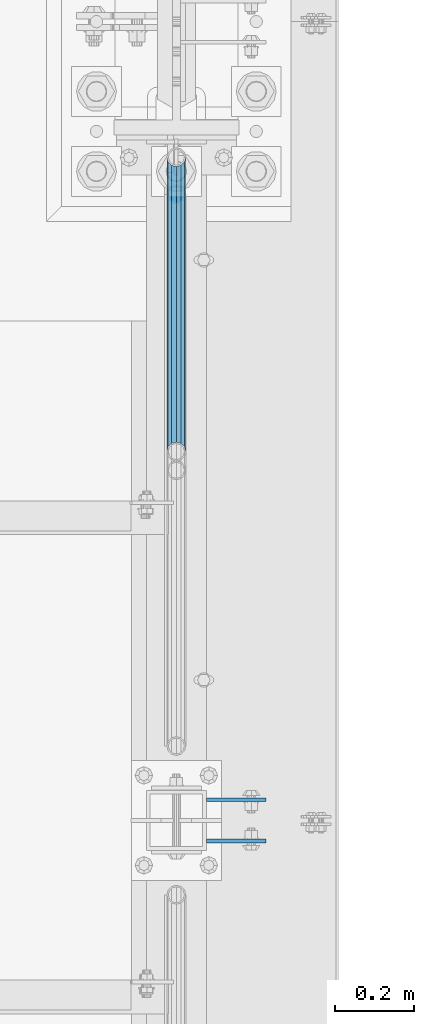
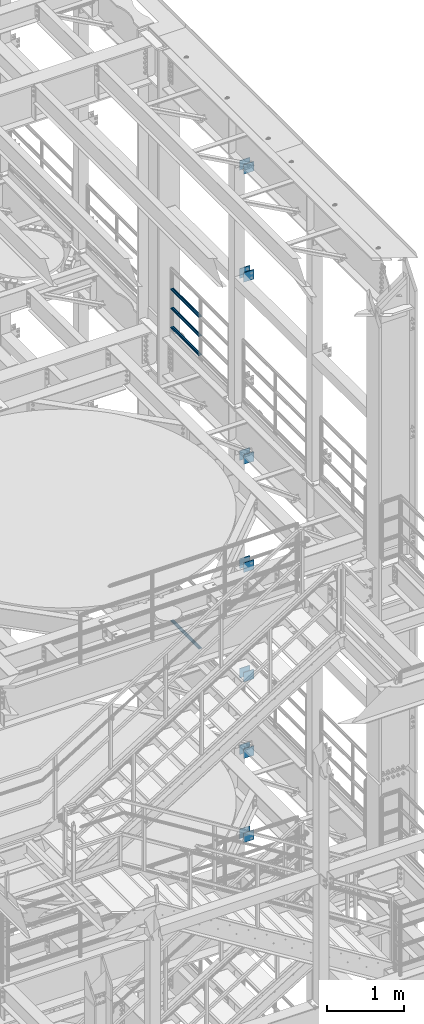
# One storey, part 1269 of 1876: 18 beams, 5 elements without a shape of their own.
"""IFC2X3 building model written with IfcOpenShell, lengths in millimetres."""

from ifc_helpers import new_model, si_unit, frame, origin_with_axes, place, context, subcontext, project, spatial, faceted_brep, material, type_object, element, aggregate, save


model = new_model("IFC2X3")

# Units and contexts
model_context = context("Model", 3, precision=1e-05, world=origin_with_axes())
body_context = subcontext(model_context, "Body", "Model", "MODEL_VIEW")
ifc_project = project(units=[si_unit("LENGTHUNIT", "METRE", prefix="MILLI"), si_unit("AREAUNIT", "SQUARE_METRE"), si_unit("VOLUMEUNIT", "CUBIC_METRE"), si_unit("MASSUNIT", "GRAM", prefix="KILO"), si_unit("TIMEUNIT", "SECOND"), si_unit("PLANEANGLEUNIT", "RADIAN"), si_unit("SOLIDANGLEUNIT", "STERADIAN"), si_unit("THERMODYNAMICTEMPERATUREUNIT", "DEGREE_CELSIUS"), si_unit("LUMINOUSINTENSITYUNIT", "LUMEN")], contexts=[model_context])

# Site, building, storey
site_placement = place(None, origin_with_axes())
site = spatial("IfcSite", under=ifc_project, at=site_placement, CompositionType="ELEMENT")
building_placement = place(site_placement, origin_with_axes())
building = spatial("IfcBuilding", under=site, at=building_placement, Name="Undefined", CompositionType="ELEMENT")
storey_placement = place(building_placement, origin_with_axes())
storey = spatial("IfcBuildingStorey", under=building, at=storey_placement, Name="Undefined", CompositionType="ELEMENT", Elevation=0.0)

# Assembly, beams
assembly_1_placement = place(storey_placement, origin_with_axes())
assembly_1 = element("IfcElementAssembly", 1, at=assembly_1_placement, inside=storey, Name="BEAM", AssemblyPlace="NOTDEFINED", PredefinedType="RIGID_FRAME")
ifc_material_1 = material(Name="STEEL/A36")
beam_type_1 = type_object("IfcBeamType", PredefinedType="NOTDEFINED")
beam_1_placement = place(assembly_1_placement, frame((7696.20000025489, -455.6125, 21678.9), z_axis=(0.0, 0.0, -1.0), x_axis=(1.0, 0.0, 0.0)))
beam_1 = element("IfcBeam", 2, at=beam_1_placement, type_object=beam_type_1, material=ifc_material_1, Name="PLATE", context=body_context, shape_type="Brep", body=[
    faceted_brep([(0.0, 4.76249999999982, -76.1999999999998), (3.63797880709171e-12, 4.76249999999982, 76.1999969482422), (152.399993896484, 4.76250000000073, 76.1999969482422), (152.4, 4.76249999999982, -76.1999999999998), (3.63797880709171e-12, -4.76249999999982, 76.1999969482422), (152.399993896484, -4.76250000000073, 76.1999969482422), (0.0, -4.76249999999982, -76.1999999999998), (152.4, -4.76249999999982, -76.1999999999998)], [[[0, 1, 2, 3]], [[4, 5, 2, 1]], [[4, 6, 7, 5]], [[6, 0, 3, 7]], [[5, 7, 3, 2]], [[6, 4, 1, 0]]]),
])
beam_2_placement = place(assembly_1_placement, frame((7696.20000025489, -560.3875, 21678.9), z_axis=(0.0, 0.0, -1.0), x_axis=(1.0, 0.0, 0.0)))
beam_2 = element("IfcBeam", 3, at=beam_2_placement, type_object=beam_type_1, material=ifc_material_1, Name="PLATE", context=body_context, shape_type="Brep", body=[
    faceted_brep([(0.0, 4.76249999999982, -76.1999999999998), (3.63797880709171e-12, 4.76249999999982, 76.1999969482422), (152.399993896484, 4.76250000000073, 76.1999969482422), (152.4, 4.76249999999982, -76.1999999999998), (3.63797880709171e-12, -4.76249999999982, 76.1999969482422), (152.399993896484, -4.76250000000073, 76.1999969482422), (0.0, -4.76249999999982, -76.1999999999998), (152.4, -4.76249999999982, -76.1999999999998)], [[[0, 1, 2, 3]], [[4, 5, 2, 1]], [[4, 6, 7, 5]], [[6, 0, 3, 7]], [[5, 7, 3, 2]], [[6, 4, 1, 0]]]),
])
beam_3_placement = place(assembly_1_placement, frame((7696.20000025489, -455.6125, 19958.05), z_axis=(0.0, 0.0, -1.0), x_axis=(1.0, 0.0, 0.0)))
beam_3 = element("IfcBeam", 4, at=beam_3_placement, type_object=beam_type_1, material=ifc_material_1, Name="PLATE", context=body_context, shape_type="Brep", body=[
    faceted_brep([(0.0, 4.76249999999982, -76.1999999999998), (3.63797880709171e-12, 4.76249999999982, 76.1999969482422), (152.399993896484, 4.76250000000073, 76.1999969482422), (152.4, 4.76249999999982, -76.1999999999998), (3.63797880709171e-12, -4.76249999999982, 76.1999969482422), (152.399993896484, -4.76250000000073, 76.1999969482422), (0.0, -4.76249999999982, -76.1999999999998), (152.4, -4.76249999999982, -76.1999999999998)], [[[0, 1, 2, 3]], [[4, 5, 2, 1]], [[4, 6, 7, 5]], [[6, 0, 3, 7]], [[5, 7, 3, 2]], [[6, 4, 1, 0]]]),
])
beam_4_placement = place(assembly_1_placement, frame((7696.20000025489, -560.3875, 19958.05), z_axis=(0.0, 0.0, -1.0), x_axis=(1.0, 0.0, 0.0)))
beam_4 = element("IfcBeam", 5, at=beam_4_placement, type_object=beam_type_1, material=ifc_material_1, Name="PLATE", context=body_context, shape_type="Brep", body=[
    faceted_brep([(0.0, 4.76249999999982, -76.1999999999998), (3.63797880709171e-12, 4.76249999999982, 76.1999969482422), (152.399993896484, 4.76250000000073, 76.1999969482422), (152.4, 4.76249999999982, -76.1999999999998), (3.63797880709171e-12, -4.76249999999982, 76.1999969482422), (152.399993896484, -4.76250000000073, 76.1999969482422), (0.0, -4.76249999999982, -76.1999999999998), (152.4, -4.76249999999982, -76.1999999999998)], [[[0, 1, 2, 3]], [[4, 5, 2, 1]], [[4, 6, 7, 5]], [[6, 0, 3, 7]], [[5, 7, 3, 2]], [[6, 4, 1, 0]]]),
])
aggregate(assembly_1, [beam_1, beam_2, beam_3, beam_4])

assembly_2_placement = place(storey_placement, origin_with_axes())
assembly_2 = element("IfcElementAssembly", 6, at=assembly_2_placement, inside=storey, Name="BEAM", AssemblyPlace="NOTDEFINED", PredefinedType="RIGID_FRAME")
beam_5_placement = place(assembly_2_placement, frame((7696.2, -455.6125, 13589.0), z_axis=(0.0, 0.0, -1.0), x_axis=(1.0, 0.0, 0.0)))
beam_5 = element("IfcBeam", 7, at=beam_5_placement, type_object=beam_type_1, material=ifc_material_1, Name="PLATE", context=body_context, shape_type="Brep", body=[
    faceted_brep([(0.0, 4.76249999999982, -76.1999999999998), (3.63797880709171e-12, 4.76249999999982, 76.1999969482422), (152.399993896484, 4.76250000000073, 76.1999969482422), (152.4, 4.76249999999982, -76.1999999999998), (3.63797880709171e-12, -4.76249999999982, 76.1999969482422), (152.399993896484, -4.76250000000073, 76.1999969482422), (0.0, -4.76249999999982, -76.1999999999998), (152.4, -4.76249999999982, -76.1999999999998)], [[[0, 1, 2, 3]], [[4, 5, 2, 1]], [[4, 6, 7, 5]], [[6, 0, 3, 7]], [[5, 7, 3, 2]], [[6, 4, 1, 0]]]),
])
beam_6_placement = place(assembly_2_placement, frame((7696.2, -560.3875, 13589.0), z_axis=(0.0, 0.0, -1.0), x_axis=(1.0, 0.0, 0.0)))
beam_6 = element("IfcBeam", 8, at=beam_6_placement, type_object=beam_type_1, material=ifc_material_1, Name="PLATE", context=body_context, shape_type="Brep", body=[
    faceted_brep([(0.0, 4.76249999999982, -76.1999999999998), (3.63797880709171e-12, 4.76249999999982, 76.1999969482422), (152.399993896484, 4.76250000000073, 76.1999969482422), (152.4, 4.76249999999982, -76.1999999999998), (3.63797880709171e-12, -4.76249999999982, 76.1999969482422), (152.399993896484, -4.76250000000073, 76.1999969482422), (0.0, -4.76249999999982, -76.1999999999998), (152.4, -4.76249999999982, -76.1999999999998)], [[[0, 1, 2, 3]], [[4, 5, 2, 1]], [[4, 6, 7, 5]], [[6, 0, 3, 7]], [[5, 7, 3, 2]], [[6, 4, 1, 0]]]),
])
beam_7_placement = place(assembly_2_placement, frame((7696.2, -455.6125, 17056.1), z_axis=(0.0, 0.0, -1.0), x_axis=(1.0, 0.0, 0.0)))
beam_7 = element("IfcBeam", 9, at=beam_7_placement, type_object=beam_type_1, material=ifc_material_1, Name="PLATE", context=body_context, shape_type="Brep", body=[
    faceted_brep([(0.0, 4.76249999999982, -76.1999999999998), (3.63797880709171e-12, 4.76249999999982, 76.1999969482422), (152.399993896484, 4.76250000000073, 76.1999969482422), (152.4, 4.76249999999982, -76.1999999999998), (3.63797880709171e-12, -4.76249999999982, 76.1999969482422), (152.399993896484, -4.76250000000073, 76.1999969482422), (0.0, -4.76249999999982, -76.1999999999998), (152.4, -4.76249999999982, -76.1999999999998)], [[[0, 1, 2, 3]], [[4, 5, 2, 1]], [[4, 6, 7, 5]], [[6, 0, 3, 7]], [[5, 7, 3, 2]], [[6, 4, 1, 0]]]),
])
beam_8_placement = place(assembly_2_placement, frame((7696.2, -560.3875, 17056.1), z_axis=(0.0, 0.0, -1.0), x_axis=(1.0, 0.0, 0.0)))
beam_8 = element("IfcBeam", 10, at=beam_8_placement, type_object=beam_type_1, material=ifc_material_1, Name="PLATE", context=body_context, shape_type="Brep", body=[
    faceted_brep([(0.0, 4.76249999999982, -76.1999999999998), (3.63797880709171e-12, 4.76249999999982, 76.1999969482422), (152.399993896484, 4.76250000000073, 76.1999969482422), (152.4, 4.76249999999982, -76.1999999999998), (3.63797880709171e-12, -4.76249999999982, 76.1999969482422), (152.399993896484, -4.76250000000073, 76.1999969482422), (0.0, -4.76249999999982, -76.1999999999998), (152.4, -4.76249999999982, -76.1999999999998)], [[[0, 1, 2, 3]], [[4, 5, 2, 1]], [[4, 6, 7, 5]], [[6, 0, 3, 7]], [[5, 7, 3, 2]], [[6, 4, 1, 0]]]),
])
beam_9_placement = place(assembly_2_placement, frame((7696.2, -455.6125, 15335.25), z_axis=(0.0, 0.0, -1.0), x_axis=(1.0, 0.0, 0.0)))
beam_9 = element("IfcBeam", 11, at=beam_9_placement, type_object=beam_type_1, material=ifc_material_1, Name="PLATE", context=body_context, shape_type="Brep", body=[
    faceted_brep([(0.0, 4.76249999999982, -76.1999999999998), (3.63797880709171e-12, 4.76249999999982, 76.1999969482422), (152.399993896484, 4.76250000000073, 76.1999969482422), (152.4, 4.76249999999982, -76.1999999999998), (3.63797880709171e-12, -4.76249999999982, 76.1999969482422), (152.399993896484, -4.76250000000073, 76.1999969482422), (0.0, -4.76249999999982, -76.1999999999998), (152.4, -4.76249999999982, -76.1999999999998)], [[[0, 1, 2, 3]], [[4, 5, 2, 1]], [[4, 6, 7, 5]], [[6, 0, 3, 7]], [[5, 7, 3, 2]], [[6, 4, 1, 0]]]),
])
beam_10_placement = place(assembly_2_placement, frame((7696.2, -560.3875, 15335.25), z_axis=(0.0, 0.0, -1.0), x_axis=(1.0, 0.0, 0.0)))
beam_10 = element("IfcBeam", 12, at=beam_10_placement, type_object=beam_type_1, material=ifc_material_1, Name="PLATE", context=body_context, shape_type="Brep", body=[
    faceted_brep([(0.0, 4.76249999999982, -76.1999999999998), (3.63797880709171e-12, 4.76249999999982, 76.1999969482422), (152.399993896484, 4.76250000000073, 76.1999969482422), (152.4, 4.76249999999982, -76.1999999999998), (3.63797880709171e-12, -4.76249999999982, 76.1999969482422), (152.399993896484, -4.76250000000073, 76.1999969482422), (0.0, -4.76249999999982, -76.1999999999998), (152.4, -4.76249999999982, -76.1999999999998)], [[[0, 1, 2, 3]], [[4, 5, 2, 1]], [[4, 6, 7, 5]], [[6, 0, 3, 7]], [[5, 7, 3, 2]], [[6, 4, 1, 0]]]),
])
aggregate(assembly_2, [beam_5, beam_6, beam_7, beam_8, beam_9, beam_10])

assembly_3_placement = place(storey_placement, origin_with_axes())
assembly_3 = element("IfcElementAssembly", 13, at=assembly_3_placement, inside=storey, Name="BEAM", AssemblyPlace="NOTDEFINED", PredefinedType="RIGID_FRAME")
beam_11_placement = place(assembly_3_placement, frame((7696.2, -455.6125, 12369.8), z_axis=(0.0, 0.0, -1.0), x_axis=(1.0, 0.0, 0.0)))
beam_11 = element("IfcBeam", 14, at=beam_11_placement, type_object=beam_type_1, material=ifc_material_1, Name="PLATE", context=body_context, shape_type="Brep", body=[
    faceted_brep([(0.0, 4.76249999999982, -76.1999999999998), (3.63797880709171e-12, 4.76249999999982, 76.1999969482422), (152.399993896484, 4.76250000000073, 76.1999969482422), (152.4, 4.76249999999982, -76.1999999999998), (3.63797880709171e-12, -4.76249999999982, 76.1999969482422), (152.399993896484, -4.76250000000073, 76.1999969482422), (0.0, -4.76249999999982, -76.1999999999998), (152.4, -4.76249999999982, -76.1999999999998)], [[[0, 1, 2, 3]], [[4, 5, 2, 1]], [[4, 6, 7, 5]], [[6, 0, 3, 7]], [[5, 7, 3, 2]], [[6, 4, 1, 0]]]),
])
beam_12_placement = place(assembly_3_placement, frame((7696.2, -560.3875, 12369.8), z_axis=(0.0, 0.0, -1.0), x_axis=(1.0, 0.0, 0.0)))
beam_12 = element("IfcBeam", 15, at=beam_12_placement, type_object=beam_type_1, material=ifc_material_1, Name="PLATE", context=body_context, shape_type="Brep", body=[
    faceted_brep([(0.0, 4.76249999999982, -76.1999999999998), (3.63797880709171e-12, 4.76249999999982, 76.1999969482422), (152.399993896484, 4.76250000000073, 76.1999969482422), (152.4, 4.76249999999982, -76.1999999999998), (3.63797880709171e-12, -4.76249999999982, 76.1999969482422), (152.399993896484, -4.76250000000073, 76.1999969482422), (0.0, -4.76249999999982, -76.1999999999998), (152.4, -4.76249999999982, -76.1999999999998)], [[[0, 1, 2, 3]], [[4, 5, 2, 1]], [[4, 6, 7, 5]], [[6, 0, 3, 7]], [[5, 7, 3, 2]], [[6, 4, 1, 0]]]),
])
beam_13_placement = place(assembly_3_placement, frame((7696.2, -455.6125, 11029.95), z_axis=(0.0, 0.0, -1.0), x_axis=(1.0, 0.0, 0.0)))
beam_13 = element("IfcBeam", 16, at=beam_13_placement, type_object=beam_type_1, material=ifc_material_1, Name="PLATE", context=body_context, shape_type="Brep", body=[
    faceted_brep([(0.0, 4.76249999999982, -76.1999999999998), (3.63797880709171e-12, 4.76249999999982, 76.1999969482422), (152.399993896484, 4.76250000000073, 76.1999969482422), (152.4, 4.76249999999982, -76.1999999999998), (3.63797880709171e-12, -4.76249999999982, 76.1999969482422), (152.399993896484, -4.76250000000073, 76.1999969482422), (0.0, -4.76249999999982, -76.1999999999998), (152.4, -4.76249999999982, -76.1999999999998)], [[[0, 1, 2, 3]], [[4, 5, 2, 1]], [[4, 6, 7, 5]], [[6, 0, 3, 7]], [[5, 7, 3, 2]], [[6, 4, 1, 0]]]),
])
beam_14_placement = place(assembly_3_placement, frame((7696.2, -560.3875, 11029.95), z_axis=(0.0, 0.0, -1.0), x_axis=(1.0, 0.0, 0.0)))
beam_14 = element("IfcBeam", 17, at=beam_14_placement, type_object=beam_type_1, material=ifc_material_1, Name="PLATE", context=body_context, shape_type="Brep", body=[
    faceted_brep([(0.0, 4.76249999999982, -76.1999999999998), (3.63797880709171e-12, 4.76249999999982, 76.1999969482422), (152.399993896484, 4.76250000000073, 76.1999969482422), (152.4, 4.76249999999982, -76.1999999999998), (3.63797880709171e-12, -4.76249999999982, 76.1999969482422), (152.399993896484, -4.76250000000073, 76.1999969482422), (0.0, -4.76249999999982, -76.1999999999998), (152.4, -4.76249999999982, -76.1999999999998)], [[[0, 1, 2, 3]], [[4, 5, 2, 1]], [[4, 6, 7, 5]], [[6, 0, 3, 7]], [[5, 7, 3, 2]], [[6, 4, 1, 0]]]),
])
aggregate(assembly_3, [beam_11, beam_12, beam_13, beam_14])

assembly_4_placement = place(storey_placement, origin_with_axes())
assembly_4 = element("IfcElementAssembly", 18, at=assembly_4_placement, inside=storey, Name="RAIL", AssemblyPlace="NOTDEFINED", PredefinedType="RIGID_FRAME")
ifc_material_2 = material()
beam_type_2 = type_object("IfcBeamType", Name="PIPE1-1/2SCH40", PredefinedType="NOTDEFINED")
beam_15_placement = place(assembly_4_placement, frame((7619.99999999999, 1179.195, 18145.125), z_axis=(0.0, 0.0, 1.0), x_axis=(0.0, -1.0, 0.0)))
beam_15 = element("IfcBeam", 19, at=beam_15_placement, type_object=beam_type_2, material=ifc_material_2, Name="RAIL", ObjectType="PIPE1-1/2SCH40", context=body_context, shape_type="Brep", body=[
    faceted_brep([(728.085307006683, -12.0649999999996, 20.8971929933177), (728.085307006683, -12.0649999999996, 15.8661214311796), (727.591878568821, -10.2235000000001, 17.7076214311819), (724.852500000002, 0.0, 20.4470000000001), (724.852500000002, 0.0, 24.130000000001), (727.591878568821, 10.2235000000001, 17.7076214311819), (728.085307006683, 12.0649999999996, 15.8661214311796), (728.085307006683, 12.0649999999996, 20.8971929933177), (748.982500000002, 24.1300000000001, 0.0), (736.917500000002, 20.8971929933186, 12.0649999999987), (736.917500000002, 20.8971929933186, -12.0649999999987), (733.727928437864, 17.7076214311801, 10.2235000000001), (736.467307006683, 20.4470000000001, 0.0), (733.727928437864, 17.7076214311801, -10.2235000000001), (728.085307006683, 12.0649999999996, -15.8661214311796), (728.085307006683, 12.0649999999996, -20.8971929933177), (727.591878568821, 10.2235000000001, -17.7076214311819), (724.852500000002, 0.0, -20.4470000000001), (724.852500000002, 0.0, -24.130000000001), (728.085307006683, -12.0649999999996, -15.8661214311796), (728.085307006683, -12.0649999999996, -20.8971929933177), (727.591878568821, -10.2235000000001, -17.7076214311819), (748.982500000002, -24.1300000000001, 0.0), (736.917500000002, -20.8971929933186, -12.0649999999987), (736.917500000002, -20.8971929933186, 12.0649999999987), (733.727928437864, -17.7076214311801, -10.2235000000001), (736.467307006683, -20.4470000000001, 0.0), (733.727928437864, -17.7076214311801, 10.2235000000001), (12.0650000000064, -20.8971929933177, -12.0649999999987), (20.8971929933249, -12.0650000000005, -20.8971929933177), (0.0, 24.1299999999992, 0.0), (12.0650000000064, 20.8971929933177, -12.0649999999987), (12.0650000000064, 20.8971929933177, 12.0649999999987), (20.8971929933249, 12.0650000000005, 20.8971929933177), (24.1300000000064, 0.0, 24.130000000001), (20.8971929933249, 12.0650000000005, -20.8971929933177), (24.1300000000063, 0.0, -24.130000000001), (24.1300000000063, 0.0, -20.4470000000001), (20.8971929933249, -12.0650000000005, -15.8661214311796), (21.3906214311868, -10.2235000000001, -17.7076214311819), (21.3906214311868, 10.2235000000001, -17.7076214311819), (20.8971929933249, 12.0650000000005, -15.8661214311796), (15.2545715621445, 17.7076214311801, -10.2235000000001), (12.5151929933249, 20.4470000000001, 0.0), (15.2545715621445, 17.7076214311801, 10.2235000000001), (20.8971929933249, 12.0650000000005, 15.8661214311796), (21.3906214311868, 10.2235000000001, 17.7076214311819), (24.1300000000064, 0.0, 20.4470000000001), (21.3906214311868, -10.2235000000001, 17.7076214311819), (20.8971929933249, -12.0650000000005, 15.8661214311796), (20.8971929933249, -12.0650000000005, 20.8971929933177), (12.0650000000064, -20.8971929933177, 12.0649999999987), (0.0, -24.1299999999992, 0.0), (15.2545715621445, -17.7076214311801, 10.2235000000001), (12.5151929933249, -20.4470000000001, 0.0), (15.2545715621445, -17.7076214311801, -10.2235000000001)], [[[0, 1, 2, 3, 4]], [[4, 3, 5, 6, 7]], [[8, 9, 10]], [[7, 6, 11, 12, 13, 14, 15, 10, 9]], [[16, 17, 18, 15, 14]], [[19, 20, 18, 17, 21]], [[22, 23, 24]], [[24, 23, 20, 19, 25, 26, 27, 1, 0]], [[28, 29, 20, 23]], [[30, 31, 32]], [[33, 34, 4, 7]], [[32, 33, 7, 9]], [[30, 32, 9, 8]], [[31, 30, 8, 10]], [[35, 31, 10, 15]], [[36, 35, 15, 18]], [[29, 36, 18, 20]], [[37, 36, 29, 38, 39]], [[40, 41, 35, 36, 37]], [[32, 31, 35, 41, 42, 43, 44, 45, 33]], [[33, 45, 46, 47, 34]], [[34, 47, 48, 49, 50]], [[34, 50, 0, 4]], [[50, 51, 24, 0]], [[51, 52, 22, 24]], [[52, 28, 23, 22]], [[51, 28, 52]], [[50, 49, 53, 54, 55, 38, 29, 28, 51]], [[55, 54, 26, 25]], [[21, 39, 38, 55, 25, 19]], [[37, 39, 21, 17]], [[40, 37, 17, 16]], [[42, 41, 40, 16, 14, 13]], [[43, 42, 13, 12]], [[44, 43, 12, 11]], [[5, 46, 45, 44, 11, 6]], [[47, 46, 5, 3]], [[48, 47, 3, 2]], [[53, 49, 48, 2, 1, 27]], [[54, 53, 27, 26]]]),
])
beam_16_placement = place(assembly_4_placement, frame((7620.0, 430.212499999997, 18449.925), z_axis=(0.0, 0.0, -1.0), x_axis=(0.0, 1.0, 0.0)))
beam_16 = element("IfcBeam", 20, at=beam_16_placement, type_object=beam_type_2, material=ifc_material_2, Name="RAIL", ObjectType="PIPE1-1/2SCH40", context=body_context, shape_type="Brep", body=[
    faceted_brep([(0.0, 24.1299999999992, 0.0), (12.0650000000064, 20.8971929933177, -12.0649999999987), (12.0650000000064, 20.8971929933177, 12.0649999999987), (12.0650000000064, -20.8971929933177, 12.0649999999987), (12.0650000000064, -20.8971929933177, -12.0649999999987), (0.0, -24.1299999999992, 0.0), (20.8971929933249, -12.0650000000005, 20.8971929933177), (20.8971929933249, -12.0650000000005, 15.8661214311796), (15.2545715621445, -17.7076214311801, 10.2235000000001), (12.5151929933249, -20.4470000000001, 0.0), (15.2545715621445, -17.7076214311801, -10.2235000000001), (20.8971929933249, -12.0650000000005, -15.8661214311796), (20.8971929933249, -12.0650000000005, -20.8971929933177), (24.1300000000063, 0.0, -20.4470000000001), (24.1300000000063, 0.0, -24.130000000001), (21.3906214311868, -10.2235000000001, -17.7076214311819), (21.3906214311868, 10.2235000000001, -17.7076214311819), (20.8971929933249, 12.0650000000005, -15.8661214311796), (20.8971929933249, 12.0650000000005, -20.8971929933177), (15.2545715621445, 17.7076214311801, -10.2235000000001), (12.5151929933249, 20.4470000000001, 0.0), (15.2545715621445, 17.7076214311801, 10.2235000000001), (20.8971929933249, 12.0650000000005, 15.8661214311796), (20.8971929933249, 12.0650000000005, 20.8971929933177), (21.3906214311868, 10.2235000000001, 17.7076214311819), (24.1300000000064, 0.0, 20.4470000000001), (24.1300000000064, 0.0, 24.130000000001), (21.3906214311868, -10.2235000000001, 17.7076214311819), (748.982500000002, 24.1300000000001, 0.0), (736.917500000002, 20.8971929933186, -12.0649999999987), (728.085307006683, 12.0649999999996, -20.8971929933177), (748.982500000002, -24.1300000000001, 0.0), (736.917500000002, -20.8971929933186, -12.0649999999987), (736.917500000002, -20.8971929933186, 12.0649999999987), (728.085307006683, -12.0649999999996, 20.8971929933177), (728.085307006683, -12.0649999999996, -20.8971929933177), (724.852500000002, 0.0, -24.130000000001), (727.591878568821, 10.2235000000001, -17.7076214311819), (724.852500000002, 0.0, -20.4470000000001), (728.085307006683, 12.0649999999996, -15.8661214311796), (728.085307006683, -12.0649999999996, -15.8661214311796), (727.591878568821, -10.2235000000001, -17.7076214311819), (733.727928437864, -17.7076214311801, -10.2235000000001), (736.467307006683, -20.4470000000001, 0.0), (733.727928437864, -17.7076214311801, 10.2235000000001), (728.085307006683, -12.0649999999996, 15.8661214311796), (727.591878568821, -10.2235000000001, 17.7076214311819), (724.852500000002, 0.0, 20.4470000000001), (724.852500000002, 0.0, 24.130000000001), (728.085307006683, 12.0649999999996, 20.8971929933177), (736.917500000002, 20.8971929933186, 12.0649999999987), (728.085307006683, 12.0649999999996, 15.8661214311796), (733.727928437864, 17.7076214311801, 10.2235000000001), (736.467307006683, 20.4470000000001, 0.0), (733.727928437864, 17.7076214311801, -10.2235000000001), (727.591878568821, 10.2235000000001, 17.7076214311819)], [[[0, 1, 2]], [[3, 4, 5]], [[6, 7, 8, 9, 10, 11, 12, 4, 3]], [[13, 14, 12, 11, 15]], [[16, 17, 18, 14, 13]], [[2, 1, 18, 17, 19, 20, 21, 22, 23]], [[23, 22, 24, 25, 26]], [[26, 25, 27, 7, 6]], [[1, 0, 28, 29]], [[18, 1, 29, 30]], [[31, 32, 33]], [[6, 3, 33, 34]], [[3, 5, 31, 33]], [[5, 4, 32, 31]], [[4, 12, 35, 32]], [[12, 14, 36, 35]], [[14, 18, 30, 36]], [[37, 38, 36, 30, 39]], [[40, 35, 36, 38, 41]], [[33, 32, 35, 40, 42, 43, 44, 45, 34]], [[34, 45, 46, 47, 48]], [[26, 6, 34, 48]], [[2, 23, 49, 50]], [[23, 26, 48, 49]], [[0, 2, 50, 28]], [[28, 50, 29]], [[49, 51, 52, 53, 54, 39, 30, 29, 50]], [[48, 47, 55, 51, 49]], [[25, 24, 55, 47]], [[55, 24, 22, 21, 52, 51]], [[21, 20, 53, 52]], [[20, 19, 54, 53]], [[19, 17, 16, 37, 39, 54]], [[16, 13, 38, 37]], [[13, 15, 41, 38]], [[41, 15, 11, 10, 42, 40]], [[10, 9, 43, 42]], [[9, 8, 44, 43]], [[8, 7, 27, 46, 45, 44]], [[27, 25, 47, 46]]]),
])
beam_17_placement = place(assembly_4_placement, frame((7620.0, 430.212499999997, 18754.725), z_axis=(0.0, 0.0, -1.0), x_axis=(0.0, 1.0, 0.0)))
beam_17 = element("IfcBeam", 21, at=beam_17_placement, type_object=beam_type_2, material=ifc_material_2, Name="RAIL", ObjectType="PIPE1-1/2SCH40", context=body_context, shape_type="Brep", body=[
    faceted_brep([(0.0, 24.1299999999992, 0.0), (12.0650000000064, 20.8971929933177, -12.0649999999987), (12.0650000000064, 20.8971929933177, 12.0649999999987), (12.0650000000064, -20.8971929933177, 12.0649999999987), (12.0650000000064, -20.8971929933177, -12.0649999999987), (0.0, -24.1299999999992, 0.0), (20.8971929933249, -12.0650000000005, 20.8971929933177), (20.8971929933249, -12.0650000000005, 15.8661214311796), (15.2545715621445, -17.7076214311801, 10.2235000000001), (12.5151929933249, -20.4470000000001, 0.0), (15.2545715621445, -17.7076214311801, -10.2235000000001), (20.8971929933249, -12.0650000000005, -15.8661214311796), (20.8971929933249, -12.0650000000005, -20.8971929933177), (24.1300000000063, 0.0, -20.4470000000001), (24.1300000000063, 0.0, -24.130000000001), (21.3906214311868, -10.2235000000001, -17.7076214311819), (21.3906214311868, 10.2235000000001, -17.7076214311819), (20.8971929933249, 12.0650000000005, -15.8661214311796), (20.8971929933249, 12.0650000000005, -20.8971929933177), (15.2545715621445, 17.7076214311801, -10.2235000000001), (12.5151929933249, 20.4470000000001, 0.0), (15.2545715621445, 17.7076214311801, 10.2235000000001), (20.8971929933249, 12.0650000000005, 15.8661214311796), (20.8971929933249, 12.0650000000005, 20.8971929933177), (21.3906214311868, 10.2235000000001, 17.7076214311819), (24.1300000000064, 0.0, 20.4470000000001), (24.1300000000064, 0.0, 24.130000000001), (21.3906214311868, -10.2235000000001, 17.7076214311819), (748.982500000002, 24.1300000000001, 0.0), (736.917500000002, 20.8971929933186, -12.0649999999987), (728.085307006683, 12.0649999999996, -20.8971929933177), (748.982500000002, -24.1300000000001, 0.0), (736.917500000002, -20.8971929933186, -12.0649999999987), (736.917500000002, -20.8971929933186, 12.0649999999987), (728.085307006683, -12.0649999999996, 20.8971929933177), (728.085307006683, -12.0649999999996, -20.8971929933177), (724.852500000002, 0.0, -24.130000000001), (727.591878568821, 10.2235000000001, -17.7076214311819), (724.852500000002, 0.0, -20.4470000000001), (728.085307006683, 12.0649999999996, -15.8661214311796), (728.085307006683, -12.0649999999996, -15.8661214311796), (727.591878568821, -10.2235000000001, -17.7076214311819), (733.727928437864, -17.7076214311801, -10.2235000000001), (736.467307006683, -20.4470000000001, 0.0), (733.727928437864, -17.7076214311801, 10.2235000000001), (728.085307006683, -12.0649999999996, 15.8661214311796), (727.591878568821, -10.2235000000001, 17.7076214311819), (724.852500000002, 0.0, 20.4470000000001), (724.852500000002, 0.0, 24.130000000001), (728.085307006683, 12.0649999999996, 20.8971929933177), (736.917500000002, 20.8971929933186, 12.0649999999987), (728.085307006683, 12.0649999999996, 15.8661214311796), (733.727928437864, 17.7076214311801, 10.2235000000001), (736.467307006683, 20.4470000000001, 0.0), (733.727928437864, 17.7076214311801, -10.2235000000001), (727.591878568821, 10.2235000000001, 17.7076214311819)], [[[0, 1, 2]], [[3, 4, 5]], [[6, 7, 8, 9, 10, 11, 12, 4, 3]], [[13, 14, 12, 11, 15]], [[16, 17, 18, 14, 13]], [[2, 1, 18, 17, 19, 20, 21, 22, 23]], [[23, 22, 24, 25, 26]], [[26, 25, 27, 7, 6]], [[1, 0, 28, 29]], [[18, 1, 29, 30]], [[31, 32, 33]], [[6, 3, 33, 34]], [[3, 5, 31, 33]], [[5, 4, 32, 31]], [[4, 12, 35, 32]], [[12, 14, 36, 35]], [[14, 18, 30, 36]], [[37, 38, 36, 30, 39]], [[40, 35, 36, 38, 41]], [[33, 32, 35, 40, 42, 43, 44, 45, 34]], [[34, 45, 46, 47, 48]], [[26, 6, 34, 48]], [[2, 23, 49, 50]], [[23, 26, 48, 49]], [[0, 2, 50, 28]], [[28, 50, 29]], [[49, 51, 52, 53, 54, 39, 30, 29, 50]], [[48, 47, 55, 51, 49]], [[25, 24, 55, 47]], [[55, 24, 22, 21, 52, 51]], [[21, 20, 53, 52]], [[20, 19, 54, 53]], [[19, 17, 16, 37, 39, 54]], [[16, 13, 38, 37]], [[13, 15, 41, 38]], [[41, 15, 11, 10, 42, 40]], [[10, 9, 43, 42]], [[9, 8, 44, 43]], [[8, 7, 27, 46, 45, 44]], [[27, 25, 47, 46]]]),
])
aggregate(assembly_4, [beam_15, beam_16, beam_17])

# Assembly, beam
assembly_5_placement = place(storey_placement, origin_with_axes())
assembly_5 = element("IfcElementAssembly", 22, at=assembly_5_placement, inside=storey, Name="RAIL", AssemblyPlace="NOTDEFINED", PredefinedType="RIGID_FRAME")
beam_18_placement = place(assembly_5_placement, frame((7619.99999999999, 1179.195, 13471.525), z_axis=(0.0, 0.0, 1.0), x_axis=(0.0, -1.0, 0.0)))
beam_18 = element("IfcBeam", 23, at=beam_18_placement, type_object=beam_type_2, material=ifc_material_2, Name="RAIL", ObjectType="PIPE1-1/2SCH40", context=body_context, shape_type="Brep", body=[
    faceted_brep([(728.085307006683, -12.0649999999996, 20.8971929933177), (728.085307006683, -12.0649999999996, 15.8661214311796), (727.591878568821, -10.2235000000001, 17.7076214311819), (724.852500000002, 0.0, 20.4470000000001), (724.852500000002, 0.0, 24.130000000001), (727.591878568821, 10.2235000000001, 17.7076214311819), (728.085307006683, 12.0649999999996, 15.8661214311796), (728.085307006683, 12.0649999999996, 20.8971929933177), (748.982500000002, 24.1300000000001, 0.0), (736.917500000002, 20.8971929933186, 12.0649999999987), (736.917500000002, 20.8971929933186, -12.0649999999987), (733.727928437864, 17.7076214311801, 10.2235000000001), (736.467307006683, 20.4470000000001, 0.0), (733.727928437864, 17.7076214311801, -10.2235000000001), (728.085307006683, 12.0649999999996, -15.8661214311796), (728.085307006683, 12.0649999999996, -20.8971929933177), (727.591878568821, 10.2235000000001, -17.7076214311819), (724.852500000002, 0.0, -20.4470000000001), (724.852500000002, 0.0, -24.130000000001), (728.085307006683, -12.0649999999996, -15.8661214311796), (728.085307006683, -12.0649999999996, -20.8971929933177), (727.591878568821, -10.2235000000001, -17.7076214311819), (748.982500000002, -24.1300000000001, 0.0), (736.917500000002, -20.8971929933186, -12.0649999999987), (736.917500000002, -20.8971929933186, 12.0649999999987), (733.727928437864, -17.7076214311801, -10.2235000000001), (736.467307006683, -20.4470000000001, 0.0), (733.727928437864, -17.7076214311801, 10.2235000000001), (12.0650000000064, -20.8971929933177, -12.0649999999987), (20.8971929933249, -12.0650000000005, -20.8971929933177), (0.0, 24.1299999999992, 0.0), (12.0650000000064, 20.8971929933177, -12.0649999999987), (12.0650000000064, 20.8971929933177, 12.0649999999987), (20.8971929933249, 12.0650000000005, 20.8971929933177), (24.1300000000064, 0.0, 24.130000000001), (20.8971929933249, 12.0650000000005, -20.8971929933177), (24.1300000000063, 0.0, -24.130000000001), (24.1300000000063, 0.0, -20.4470000000001), (20.8971929933249, -12.0650000000005, -15.8661214311796), (21.3906214311868, -10.2235000000001, -17.7076214311819), (21.3906214311868, 10.2235000000001, -17.7076214311819), (20.8971929933249, 12.0650000000005, -15.8661214311796), (15.2545715621445, 17.7076214311801, -10.2235000000001), (12.5151929933249, 20.4470000000001, 0.0), (15.2545715621445, 17.7076214311801, 10.2235000000001), (20.8971929933249, 12.0650000000005, 15.8661214311796), (21.3906214311868, 10.2235000000001, 17.7076214311819), (24.1300000000064, 0.0, 20.4470000000001), (21.3906214311868, -10.2235000000001, 17.7076214311819), (20.8971929933249, -12.0650000000005, 15.8661214311796), (20.8971929933249, -12.0650000000005, 20.8971929933177), (12.0650000000064, -20.8971929933177, 12.0649999999987), (0.0, -24.1299999999992, 0.0), (15.2545715621445, -17.7076214311801, 10.2235000000001), (12.5151929933249, -20.4470000000001, 0.0), (15.2545715621445, -17.7076214311801, -10.2235000000001)], [[[0, 1, 2, 3, 4]], [[4, 3, 5, 6, 7]], [[8, 9, 10]], [[7, 6, 11, 12, 13, 14, 15, 10, 9]], [[16, 17, 18, 15, 14]], [[19, 20, 18, 17, 21]], [[22, 23, 24]], [[24, 23, 20, 19, 25, 26, 27, 1, 0]], [[28, 29, 20, 23]], [[30, 31, 32]], [[33, 34, 4, 7]], [[32, 33, 7, 9]], [[30, 32, 9, 8]], [[31, 30, 8, 10]], [[35, 31, 10, 15]], [[36, 35, 15, 18]], [[29, 36, 18, 20]], [[37, 36, 29, 38, 39]], [[40, 41, 35, 36, 37]], [[32, 31, 35, 41, 42, 43, 44, 45, 33]], [[33, 45, 46, 47, 34]], [[34, 47, 48, 49, 50]], [[34, 50, 0, 4]], [[50, 51, 24, 0]], [[51, 52, 22, 24]], [[52, 28, 23, 22]], [[51, 28, 52]], [[50, 49, 53, 54, 55, 38, 29, 28, 51]], [[55, 54, 26, 25]], [[21, 39, 38, 55, 25, 19]], [[37, 39, 21, 17]], [[40, 37, 17, 16]], [[42, 41, 40, 16, 14, 13]], [[43, 42, 13, 12]], [[44, 43, 12, 11]], [[5, 46, 45, 44, 11, 6]], [[47, 46, 5, 3]], [[48, 47, 3, 2]], [[53, 49, 48, 2, 1, 27]], [[54, 53, 27, 26]]]),
])
aggregate(assembly_5, [beam_18])

save(model, "model.ifc")
